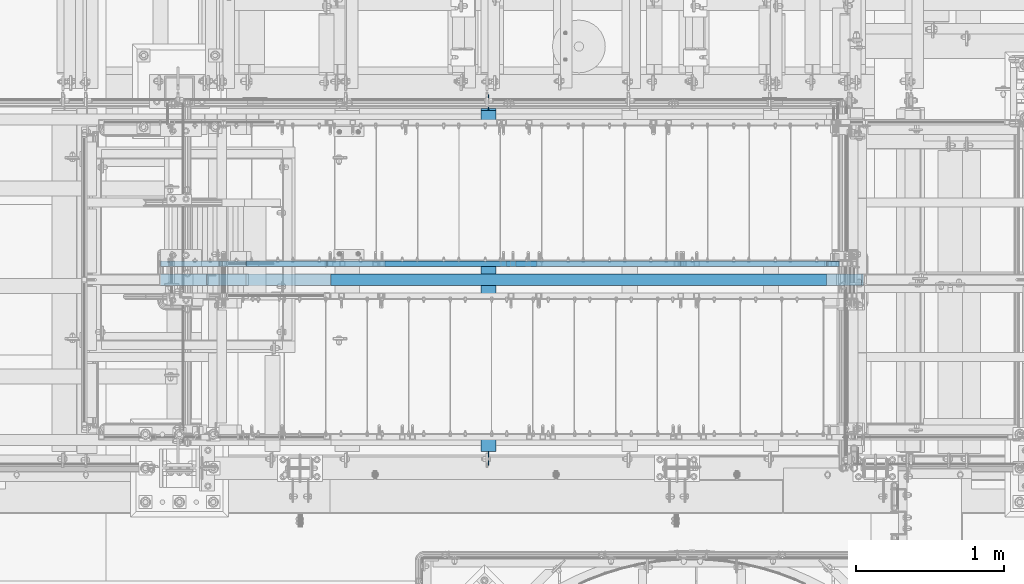
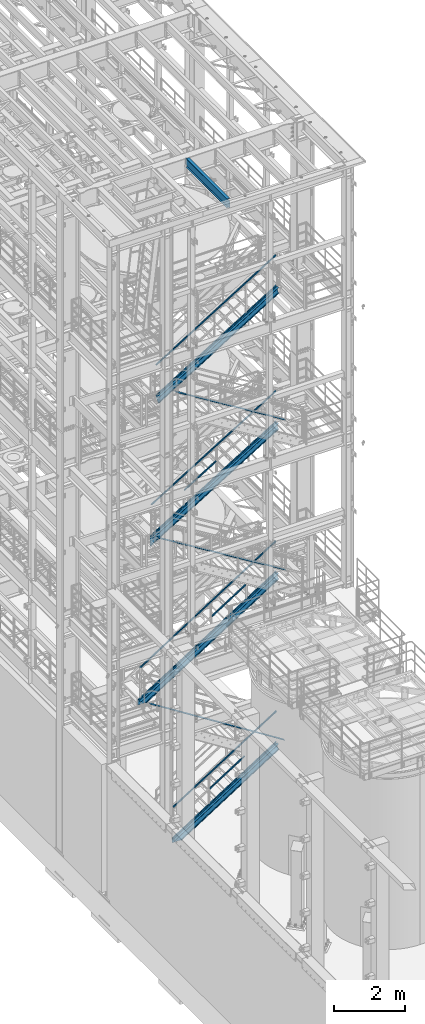
# One storey, part 975 of 1876: 18 members, 1 beam, 16 elements without a shape of their own.
"""IFC2X3 building model written with IfcOpenShell, lengths in millimetres."""

from ifc_helpers import new_model, si_unit, frame, origin_with_axes, place, context, subcontext, project, spatial, faceted_brep, material, type_object, element, aggregate, save


model = new_model("IFC2X3")

# Units and contexts
model_context = context("Model", 3, precision=1e-05, world=origin_with_axes())
body_context = subcontext(model_context, "Body", "Model", "MODEL_VIEW")
ifc_project = project(units=[si_unit("LENGTHUNIT", "METRE", prefix="MILLI"), si_unit("AREAUNIT", "SQUARE_METRE"), si_unit("VOLUMEUNIT", "CUBIC_METRE"), si_unit("MASSUNIT", "GRAM", prefix="KILO"), si_unit("TIMEUNIT", "SECOND"), si_unit("PLANEANGLEUNIT", "RADIAN"), si_unit("SOLIDANGLEUNIT", "STERADIAN"), si_unit("THERMODYNAMICTEMPERATUREUNIT", "DEGREE_CELSIUS"), si_unit("LUMINOUSINTENSITYUNIT", "LUMEN")], contexts=[model_context])

# Site, building, storey
site_placement = place(None, origin_with_axes())
site = spatial("IfcSite", under=ifc_project, at=site_placement, CompositionType="ELEMENT")
building_placement = place(site_placement, origin_with_axes())
building = spatial("IfcBuilding", under=site, at=building_placement, Name="Undefined", CompositionType="ELEMENT")
storey_placement = place(building_placement, origin_with_axes())
storey = spatial("IfcBuildingStorey", under=building, at=storey_placement, Name="Undefined", CompositionType="ELEMENT", Elevation=0.0)

# Assembly, beam
assembly_1_placement = place(storey_placement, origin_with_axes())
assembly_1 = element("IfcElementAssembly", 1, at=assembly_1_placement, inside=storey, Name="BEAM", AssemblyPlace="NOTDEFINED", PredefinedType="RIGID_FRAME")
ifc_material_1 = material(Name="STEEL/A992")
beam_type = type_object("IfcBeamType", Name="W12X16", PredefinedType="NOTDEFINED")
beam_placement = place(assembly_1_placement, frame((3810.0, -7112.0, 22402.8), z_axis=(0.0, 0.0, 1.0), x_axis=(0.0, 1.0, 0.0)))
beam = element("IfcBeam", 2, at=beam_placement, type_object=beam_type, material=ifc_material_1, Name="BEAM", ObjectType="W12X16", context=body_context, shape_type="Brep", body=[
    faceted_brep([(17.4625000000005, -3.17500000000018, -126.999999999999), (17.4625000000005, 3.17500000000018, -126.999999999999), (100.012500190734, 3.17500000000018, -126.999999999999), (100.012500190734, -3.17500000000018, -126.999999999999), (104.87257970878, 3.17500000000018, -127.966729922587), (104.87257970878, -3.17500000000018, -127.966729922587), (108.992756176934, 3.17500000000018, -130.719743823065), (108.992756176934, -3.17500000000018, -130.719743823065), (111.745770077412, 3.17500000000018, -134.839920291219), (111.745770077412, -3.17500000000018, -134.839920291219), (112.7125, -3.17500000000018, -139.699999809264), (112.7125, 3.17500000000018, -139.699999809264), (112.712500000001, 3.17500000000018, -146.049999999999), (112.7125, 50.8000000000002, -146.05), (112.7125, 50.8000000000002, -152.4), (112.7125, -50.8000000000002, -152.4), (112.7125, -50.8000000000002, -146.05), (112.712500000001, -3.17500000000018, -146.049999999999), (2412.20625, 50.8000000000002, 146.049999999999), (2412.20625, 3.17500000000018, 146.049999999999), (112.712500000001, 3.17500000000018, 146.05), (112.712500000001, 50.8000000000002, 146.049999999999), (100.012500190735, -3.17500000000018, 114.299999999996), (100.012500190735, 3.17500000000018, 114.299999999996), (17.4624999999996, 3.17500000000018, 114.299999999996), (17.4624999999996, -3.17500000000018, 114.299999999996), (104.872579708781, -3.17500000000018, 115.266729922583), (104.872579708781, 3.17500000000018, 115.266729922583), (108.992756176935, -3.17500000000018, 118.019743823061), (108.992756176935, 3.17500000000018, 118.019743823061), (111.745770077413, -3.17500000000018, 122.139920291214), (111.745770077413, 3.17500000000018, 122.139920291214), (112.712500000001, -3.17500000000018, 126.999999809261), (112.712500000001, 3.17500000000018, 126.999999809261), (2412.20625, -50.8000000000002, 152.400000000001), (2412.20625, 50.8000000000002, 152.400000000001), (112.712500000001, 50.8000000000002, 152.400000000001), (112.712500000001, -50.8000000000002, 152.400000000001), (2412.20625, -50.8000000000002, 146.049999999999), (112.712500000001, -50.8000000000002, 146.049999999999), (2412.20625, -3.17500000000018, 146.049999999999), (112.712500000001, -3.17500000000018, 146.05), (2412.20625, -3.17500000000018, 126.999999809268), (2412.20625, 3.17500000000018, 126.999999809268), (2413.17297992259, -3.17500000000018, 122.139920291222), (2413.17297992259, 3.17500000000018, 122.139920291222), (2415.92599382307, -3.17500000000018, 118.019743823068), (2415.92599382307, 3.17500000000018, 118.019743823068), (2420.04617029122, -3.17500000000018, 115.26672992259), (2420.04617029122, 3.17500000000018, 115.26672992259), (2424.90624980927, -3.17500000000018, 114.300000000003), (2424.90624980927, 3.17500000000018, 114.300000000003), (2520.15625, -3.17500000000018, 114.300000000003), (2520.15625, 3.17500000000018, 114.300000000003), (2520.15625, -3.17500000000018, -126.999999999996), (2520.15625, 3.17500000000018, -126.999999999996), (2437.60624980927, -3.17500000000018, -126.999999999996), (2437.60624980927, 3.17500000000018, -126.999999999996), (2432.74617029122, -3.17500000000018, -127.966729922584), (2432.74617029122, 3.17500000000018, -127.966729922584), (2428.62599382307, -3.17500000000018, -130.719743823061), (2428.62599382307, 3.17500000000018, -130.719743823061), (2425.87297992259, -3.17500000000018, -134.839920291215), (2425.87297992259, 3.17500000000018, -134.839920291215), (2424.90625, -3.17500000000018, -139.699999809261), (2424.90625, 3.17500000000018, -139.699999809261), (2424.90625, -3.17500000000018, -146.049999999999), (2424.90625, -50.8000000000002, -146.049999999999), (2424.90625, -50.8000000000002, -152.400000000001), (2424.90625, 50.8000000000002, -152.400000000001), (2424.90625, 50.8000000000002, -146.049999999999), (2424.90625, 3.17500000000018, -146.049999999999)], [[[0, 1, 2, 3]], [[3, 2, 4, 5]], [[5, 4, 6, 7]], [[7, 6, 8, 9]], [[10, 11, 12, 13, 14, 15, 16, 17]], [[9, 8, 11, 10]], [[18, 19, 20, 21]], [[22, 23, 24, 25]], [[26, 27, 23, 22]], [[28, 29, 27, 26]], [[30, 31, 29, 28]], [[32, 33, 31, 30]], [[34, 35, 36, 37]], [[38, 34, 37, 39]], [[40, 38, 39, 41]], [[37, 36, 21, 20, 33, 32, 41, 39]], [[35, 18, 21, 36]], [[34, 38, 40, 42, 43, 19, 18, 35]], [[44, 45, 43, 42]], [[46, 47, 45, 44]], [[48, 49, 47, 46]], [[50, 51, 49, 48]], [[52, 53, 51, 50]], [[53, 52, 54, 55]], [[54, 56, 57, 55]], [[58, 59, 57, 56]], [[60, 61, 59, 58]], [[62, 63, 61, 60]], [[64, 65, 63, 62]], [[66, 67, 68, 69, 70, 71, 65, 64]], [[67, 66, 17, 16]], [[68, 67, 16, 15]], [[69, 68, 15, 14]], [[70, 69, 14, 13]], [[71, 70, 13, 12]], [[6, 4, 2, 1, 24, 23, 27, 29, 31, 33, 20, 19, 43, 45, 47, 49, 51, 53, 55, 57, 59, 61, 63, 65, 71, 12, 11, 8]], [[25, 24, 1, 0]], [[66, 64, 62, 60, 58, 56, 54, 52, 50, 48, 46, 44, 42, 40, 41, 32, 30, 28, 26, 22, 25, 0, 3, 5, 7, 9, 10, 17]]]),
])
aggregate(assembly_1, [beam])

# Assembly, members
assembly_2_placement = place(storey_placement, origin_with_axes())
assembly_2 = element("IfcElementAssembly", 3, at=assembly_2_placement, inside=storey, Name="RAIL", AssemblyPlace="NOTDEFINED", PredefinedType="RIGID_FRAME")
ifc_material_2 = material()
member_type_1 = type_object("IfcMemberType", Name="HSS1-1/2X1-1/2X1/8", PredefinedType="NOTDEFINED")
member_1_placement = place(assembly_2_placement, frame((3911.60000001395, -5734.05000114554, 1451.89067373428), z_axis=(-0.53569741975471, 0.0, 0.844410015613355), x_axis=(0.844410015326383, 0.0, 0.535697420207059)))
member_1 = element("IfcMember", 4, at=member_1_placement, type_object=member_type_1, material=ifc_material_2, Name="RAIL", ObjectType="HSS1-1/2X1-1/2X1/8", context=body_context, shape_type="Brep", body=[
    faceted_brep([(10.4747262991696, -19.0499992349996, -19.0499992349991), (34.6455325374254, -19.0499992349996, 19.049999235012), (34.6455325374254, 19.0499992349996, 19.049999235012), (10.4747262991696, 19.0499992349996, -19.0499992349991), (32.6312986338025, 15.8749992829999, 15.8749992830109), (32.6312986338025, -15.8749992829999, 15.8749992830109), (12.4889602027924, -15.8749992829999, -15.8749992829981), (12.4889602027924, 15.8749992829999, -15.8749992829981), (1349.04246072927, 19.0499992349996, -19.049999234971), (1349.04246072927, -19.0499992349996, -19.049999234971), (1373.21326696754, -19.0499992349996, 19.0499992350346), (1373.21326696754, 19.0499992349996, 19.0499992350346), (1371.19903306392, -15.8749992829999, 15.8749992830342), (1371.19903306392, 15.8749992829999, 15.8749992830342), (1351.0566946329, 15.8749992829999, -15.8749992829707), (1351.0566946329, -15.8749992829999, -15.8749992829707)], [[[0, 1, 2, 3], [4, 5, 6, 7]], [[8, 9, 0, 3]], [[9, 10, 1, 0]], [[10, 11, 2, 1]], [[11, 8, 3, 2]], [[10, 9, 8, 11], [12, 13, 14, 15]], [[13, 12, 5, 4]], [[14, 13, 4, 7]], [[15, 14, 7, 6]], [[12, 15, 6, 5]]]),
])
member_2_placement = place(assembly_2_placement, frame((6096.0000003818, -5734.05000114554, 3371.08362061158), z_axis=(0.535697419754711, 0.0, -0.844410015613354), x_axis=(-0.844410015613354, 0.0, -0.53569741975471)))
member_2 = element("IfcMember", 5, at=member_2_placement, type_object=member_type_1, material=ifc_material_2, Name="RAIL", ObjectType="HSS1-1/2X1-1/2X1/8", context=body_context, shape_type="Brep", body=[
    faceted_brep([(-4.61079482035893, 15.8749992829999, -15.8749992830034), (-4.61079482035893, -15.8749992829999, -15.8749992830034), (3979.31187617968, -15.8749992829999, -15.8749992819418), (3979.31187617968, 15.8749992829999, -15.8749992819418), (4.61079481841625, -15.8749992829999, 15.8749992830026), (3961.85399909883, -15.8749992829999, 15.8749992840581), (4.61079481841625, 15.8749992829999, 15.8749992830026), (3961.85399909883, 15.8749992829999, 15.8749992840581), (-5.53295381194494, 19.0499992349996, -19.0499992350046), (5.53295381000225, 19.0499992349996, 19.0499992350038), (3960.10821133829, 19.0499992349996, 19.0499992360577), (3981.05766394022, 19.0499992349996, -19.0499992339418), (5.53295381000225, -19.0499992349996, 19.0499992350038), (3960.10821133829, -19.0499992349996, 19.0499992360577), (-5.53295381194494, -19.0499992349996, -19.0499992350046), (3981.05766394022, -19.0499992349996, -19.0499992339418)], [[[0, 1, 2, 3]], [[1, 4, 5, 2]], [[4, 6, 7, 5]], [[6, 0, 3, 7]], [[8, 9, 10, 11]], [[9, 12, 13, 10]], [[12, 14, 15, 13]], [[14, 8, 11, 15]], [[13, 15, 11, 10], [5, 7, 3, 2]], [[14, 12, 9, 8], [6, 4, 1, 0]]]),
])
aggregate(assembly_2, [member_1, member_2])

assembly_3_placement = place(storey_placement, origin_with_axes())
assembly_3 = element("IfcElementAssembly", 6, at=assembly_3_placement, inside=storey, Name="RAIL", AssemblyPlace="NOTDEFINED", PredefinedType="RIGID_FRAME")
member_3_placement = place(assembly_3_placement, frame((3975.0999976701, -5734.05000114554, 7346.66136059212), z_axis=(-0.536875491934336, 0.0, 0.843661487896813), x_axis=(0.843661487896813, 0.0, 0.536875491934336)))
member_3 = element("IfcMember", 7, at=member_3_placement, type_object=member_type_1, material=ifc_material_2, Name="RAIL", ObjectType="HSS1-1/2X1-1/2X1/8", context=body_context, shape_type="Brep", body=[
    faceted_brep([(10.4574188235219, -19.0499992349996, -19.0499992349946), (34.7028723789208, -19.0499992349996, 19.0499992350083), (34.7028723789208, 19.0499992349996, 19.0499992350083), (10.4574188235219, 19.0499992349996, -19.0499992349946), (32.6824178653787, 15.8749992829999, 15.8749992830085), (32.6824178653787, -15.8749992829999, 15.8749992830085), (12.4778733370622, -15.8749992829999, -15.8749992829939), (12.4778733370622, 15.8749992829999, -15.8749992829939), (1327.63263086906, 19.0499992349996, -19.0499992348527), (1327.63263086906, -19.0499992349996, -19.0499992348527), (1351.87808442446, -19.0499992349996, 19.0499992351442), (1351.87808442446, 19.0499992349996, 19.0499992351442), (1349.85762991092, -15.8749992829999, 15.8749992831449), (1349.85762991092, 15.8749992829999, 15.8749992831449), (1329.6530853826, 15.8749992829999, -15.8749992828534), (1329.6530853826, -15.8749992829999, -15.8749992828534)], [[[0, 1, 2, 3], [4, 5, 6, 7]], [[8, 9, 0, 3]], [[9, 10, 1, 0]], [[10, 11, 2, 1]], [[11, 8, 3, 2]], [[10, 9, 8, 11], [12, 13, 14, 15]], [[13, 12, 5, 4]], [[14, 13, 4, 7]], [[15, 14, 7, 6]], [[12, 15, 6, 5]]]),
])
member_4_placement = place(assembly_3_placement, frame((6081.03214535919, -5734.05000114554, 9220.19999999963), z_axis=(0.536875491934335, 0.0, -0.843661487896814), x_axis=(-0.843661487896813, 0.0, -0.536875491934336)))
member_4 = element("IfcMember", 8, at=member_4_placement, type_object=member_type_1, material=ifc_material_2, Name="RAIL", ObjectType="HSS1-1/2X1-1/2X1/8", context=body_context, shape_type="Brep", body=[
    faceted_brep([(-4.62281069927667, 15.8749992829999, -15.8749992829999), (-4.62281069927667, -15.8749992829999, -15.8749992829999), (5229.56696317395, -15.8749992829999, -15.8749992811681), (5229.56696317395, 15.8749992829999, -15.8749992811681), (4.62281070567769, -15.8749992829999, 15.8749992829999), (5212.13793187573, -15.8749992829999, 15.8749992848452), (4.62281070567769, 15.8749992829999, 15.8749992829999), (5212.13793187573, 15.8749992829999, 15.8749992848452), (-5.54737286755244, 19.0499992349996, -19.0499992349996), (5.54737287395346, 19.0499992349996, 19.0499992349996), (5210.39502869354, 19.0499992349996, 19.0499992368468), (5231.30986635614, 19.0499992349996, -19.0499992331688), (5.54737287395346, -19.0499992349996, 19.0499992349996), (5210.39502869354, -19.0499992349996, 19.0499992368468), (-5.54737286755244, -19.0499992349996, -19.0499992349996), (5231.30986635614, -19.0499992349996, -19.0499992331688)], [[[0, 1, 2, 3]], [[1, 4, 5, 2]], [[4, 6, 7, 5]], [[6, 0, 3, 7]], [[8, 9, 10, 11]], [[9, 12, 13, 10]], [[12, 14, 15, 13]], [[14, 8, 11, 15]], [[13, 15, 11, 10], [5, 7, 3, 2]], [[14, 12, 9, 8], [6, 4, 1, 0]]]),
])
aggregate(assembly_3, [member_3, member_4])

assembly_4_placement = place(storey_placement, origin_with_axes())
assembly_4 = element("IfcElementAssembly", 9, at=assembly_4_placement, inside=storey, Name="RAIL", AssemblyPlace="NOTDEFINED", PredefinedType="RIGID_FRAME")
member_5_placement = place(assembly_4_placement, frame((3092.45000026332, -5734.05000114554, 12004.8866662211), z_axis=(-0.523953411146183, 0.0, 0.851746924237639), x_axis=(0.851746924237639, 0.0, 0.523953411146184)))
member_5 = element("IfcMember", 10, at=member_5_placement, type_object=member_type_1, material=ifc_material_2, Name="RAIL", ObjectType="HSS1-1/2X1-1/2X1/8", context=body_context, shape_type="Brep", body=[
    faceted_brep([(1234.38228196586, -19.0499992349996, 19.0499992361129), (1210.94501017189, -19.0499992349996, -19.0499992339264), (1210.94501017189, 19.0499992349996, -19.0499992339264), (1234.38228196586, 19.0499992349996, 19.0499992361129), (1232.42917593412, -15.8749992829999, 15.8749992841094), (1232.42917593412, 15.8749992829999, 15.8749992841094), (1212.89811620362, 15.8749992829999, -15.874999281923), (1212.89811620362, -15.8749992829999, -15.874999281923), (10.6471616099025, 19.0499992349996, -19.0499992350033), (34.0844334038557, 19.0499992349996, 19.0499992349978), (34.0844334038557, -19.0499992349996, 19.0499992349978), (10.6471616099025, -19.0499992349996, -19.0499992350033), (32.1313273721225, 15.8749992829999, 15.874999282998), (32.1313273721225, -15.8749992829999, 15.874999282998), (12.6002676416374, -15.8749992829999, -15.8749992830035), (12.6002676416374, 15.8749992829999, -15.8749992830035)], [[[0, 1, 2, 3], [4, 5, 6, 7]], [[8, 9, 3, 2]], [[9, 10, 0, 3]], [[10, 11, 1, 0]], [[11, 8, 2, 1]], [[11, 10, 9, 8], [12, 13, 14, 15]], [[14, 13, 4, 7]], [[15, 14, 7, 6]], [[12, 15, 6, 5]], [[13, 12, 5, 4]]]),
])
member_6_placement = place(assembly_4_placement, frame((6080.51600983971, -5734.05000114554, 14376.3999999962), z_axis=(0.523953411146183, 0.0, -0.851746924237639), x_axis=(-0.851746924237639, 0.0, -0.523953411146184)))
member_6 = element("IfcMember", 11, at=member_6_placement, type_object=member_type_1, material=ifc_material_2, Name="RAIL", ObjectType="HSS1-1/2X1-1/2X1/8", context=body_context, shape_type="Brep", body=[
    faceted_brep([(-4.49184492785935, 15.8749992829999, -15.8749992829999), (-4.49184492785935, -15.8749992829999, -15.8749992829999), (4762.06386347793, -15.8749992829999, -15.8749992840985), (4762.06386347793, 15.8749992829999, -15.8749992840985), (4.49184492431232, -15.8749992829999, 15.8749992829999), (4744.31859422905, -15.8749992829999, 15.8749992819121), (4.49184492431232, 15.8749992829999, 15.8749992829999), (4744.31859422905, 15.8749992829999, 15.8749992819121), (-5.39021394007068, 19.0499992349996, -19.0499992349996), (5.39021393652274, 19.0499992349996, 19.0499992349996), (4742.54406725084, 19.0499992349996, 19.0499992339137), (4763.83839045614, 19.0499992349996, -19.0499992360983), (5.39021393652274, -19.0499992349996, 19.0499992349996), (4742.54406725084, -19.0499992349996, 19.0499992339137), (-5.39021394007068, -19.0499992349996, -19.0499992349996), (4763.83839045614, -19.0499992349996, -19.0499992360983)], [[[0, 1, 2, 3]], [[1, 4, 5, 2]], [[4, 6, 7, 5]], [[6, 0, 3, 7]], [[8, 9, 10, 11]], [[9, 12, 13, 10]], [[12, 14, 15, 13]], [[14, 8, 11, 15]], [[13, 15, 11, 10], [5, 7, 3, 2]], [[14, 12, 9, 8], [6, 4, 1, 0]]]),
])
aggregate(assembly_4, [member_5, member_6])

# Assembly, member
assembly_5_placement = place(storey_placement, origin_with_axes())
assembly_5 = element("IfcElementAssembly", 12, at=assembly_5_placement, inside=storey, Name="RAIL", AssemblyPlace="NOTDEFINED", PredefinedType="RIGID_FRAME")
member_7_placement = place(assembly_5_placement, frame((6080.62411538881, -5734.05000114554, 19050.0000003721), z_axis=(0.526627379729771, 0.0, -0.850096231563789), x_axis=(-0.850096231563789, 0.0, -0.526627379729771)))
member_7 = element("IfcMember", 13, at=member_7_placement, type_object=member_type_1, material=ifc_material_2, Name="RAIL", ObjectType="HSS1-1/2X1-1/2X1/8", context=body_context, shape_type="Brep", body=[
    faceted_brep([(-4.5187969689996, 15.8749992829999, -15.8749992829871), (-4.5187969689996, -15.8749992829999, -15.8749992829871), (4579.03162456834, -15.8749992829999, -15.8749992763478), (4579.03162456834, 15.8749992829999, -15.8749992763478), (4.51879699284473, -15.8749992829999, 15.8749992829871), (4588.06921853025, -15.8749992829999, 15.8749992896428), (4.51879699284473, 15.8749992829999, 15.8749992829871), (4588.06921853025, 15.8749992829999, 15.8749992896428), (-5.42255639234099, 19.0499992349996, -19.0499992349833), (5.42255641618613, 19.0499992349996, 19.0499992349851), (4588.97297795359, 19.0499992349996, 19.0499992416389), (4578.12786514499, 19.0499992349996, -19.0499992283476), (5.42255641618613, -19.0499992349996, 19.0499992349851), (4588.97297795359, -19.0499992349996, 19.0499992416389), (-5.42255639234099, -19.0499992349996, -19.0499992349833), (4578.12786514499, -19.0499992349996, -19.0499992283476)], [[[0, 1, 2, 3]], [[1, 4, 5, 2]], [[4, 6, 7, 5]], [[6, 0, 3, 7]], [[8, 9, 10, 11]], [[9, 12, 13, 10]], [[12, 14, 15, 13]], [[14, 8, 11, 15]], [[13, 15, 11, 10], [5, 7, 3, 2]], [[14, 12, 9, 8], [6, 4, 1, 0]]]),
])
aggregate(assembly_5, [member_7])

assembly_6_placement = place(storey_placement, origin_with_axes())
assembly_6 = element("IfcElementAssembly", 14, at=assembly_6_placement, inside=storey, Name="STRINGER", AssemblyPlace="NOTDEFINED", PredefinedType="RIGID_FRAME")
ifc_material_3 = material(Name="STEEL/A36")
member_type_2 = type_object("IfcMemberType", Name="MC12X10.6", PredefinedType="NOTDEFINED")
member_8_placement = place(assembly_6_placement, frame((2257.43103902822, -5734.05000114558, 15465.2243393473), z_axis=(-0.526650190166568, 0.0, 0.850082100268861), x_axis=(0.850082100268861, 0.0, 0.526650190166567)))
member_8 = element("IfcMember", 15, at=member_8_placement, type_object=member_type_2, material=ifc_material_3, Name="STRINGER", ObjectType="MC12X10.6", context=body_context, shape_type="Brep", body=[
    faceted_brep([(-86.7653266056568, 19.0500000000002, -152.399999999963), (-1.68647966347635e-06, 19.0500000000002, 152.400000000001), (4601.43790882204, 19.0500000000002, 152.399999997626), (4514.67258218764, 19.0500000000002, -152.400000002352), (-1.68647966347635e-06, -19.0500000000002, 152.400000000001), (4601.43790882204, -19.0500000000002, 152.399999997626), (-2.15159931068411, -19.0500000000002, 144.841595000014), (4599.28630948261, -19.0500000000002, 144.841594997624), (-2.34044946693575, 14.2875000000004, 144.178178750015), (4599.09745932636, 14.2875000000004, 144.178178747625), (-84.4248771099683, 14.2875000000004, -144.178178749964), (4517.01303168332, 14.2875000000004, -144.178178752352), (-84.6137272662218, -19.0500000000002, -144.841594999965), (4516.82418152707, -19.0500000000002, -144.841595002352), (-86.7653266056568, -19.0500000000002, -152.399999999963), (4514.67258218764, -19.0500000000002, -152.400000002352)], [[[0, 1, 2, 3]], [[1, 4, 5, 2]], [[4, 6, 7, 5]], [[6, 8, 9, 7]], [[8, 10, 11, 9]], [[10, 12, 13, 11]], [[12, 14, 15, 13]], [[14, 0, 3, 15]], [[5, 7, 9, 11, 13, 15, 3, 2]], [[14, 12, 10, 8, 6, 4, 1, 0]]]),
])
aggregate(assembly_6, [member_8])

assembly_7_placement = place(storey_placement, origin_with_axes())
assembly_7 = element("IfcElementAssembly", 16, at=assembly_7_placement, inside=storey, Name="STRINGER", AssemblyPlace="NOTDEFINED", PredefinedType="RIGID_FRAME")
member_9_placement = place(assembly_7_placement, frame((1977.66354904, -5734.05000114552, 10636.6187687464), z_axis=(-0.523953411146183, 0.0, 0.851746924237639), x_axis=(0.851746924237639, 0.0, 0.523953411146184)))
member_9 = element("IfcMember", 17, at=member_9_placement, type_object=member_type_2, material=ifc_material_3, Name="STRINGER", ObjectType="MC12X10.6", context=body_context, shape_type="Brep", body=[
    faceted_brep([(-74.6865609331826, 19.0500000000002, -152.400000000033), (112.811620947801, 19.0500000000002, 152.400000000029), (4920.47564757863, 19.0500000000002, 152.399999999499), (4834.23222109767, 19.0500000000002, -152.400000000574), (112.811620947801, -19.0500000000002, 152.400000000029), (4920.47564757863, -19.0500000000002, 152.399999999499), (108.162056658365, -19.0500000000002, 144.841595000027), (4918.33699027571, -19.0500000000002, 144.841594999496), (107.753955146864, 14.2875000000004, 144.178178750026), (4918.14927606776, 14.2875000000004, 144.178178749497), (-69.6288951322458, 14.2875000000004, -144.178178750032), (4836.55859260854, 14.2875000000004, -144.178178750573), (-70.0369966437447, -19.0500000000002, -144.84159500003), (4836.37087840059, -19.0500000000002, -144.841595000573), (-74.6865609331826, -19.0500000000002, -152.400000000033), (4834.23222109767, -19.0500000000002, -152.400000000574)], [[[0, 1, 2, 3]], [[1, 4, 5, 2]], [[4, 6, 7, 5]], [[6, 8, 9, 7]], [[8, 10, 11, 9]], [[10, 12, 13, 11]], [[12, 14, 15, 13]], [[14, 0, 3, 15]], [[5, 7, 9, 11, 13, 15, 3, 2]], [[14, 12, 10, 8, 6, 4, 1, 0]]]),
])
aggregate(assembly_7, [member_9])

assembly_8_placement = place(storey_placement, origin_with_axes())
assembly_8 = element("IfcElementAssembly", 18, at=assembly_8_placement, inside=storey, Name="STRINGER", AssemblyPlace="NOTDEFINED", PredefinedType="RIGID_FRAME")
member_10_placement = place(assembly_8_placement, frame((1420.62332830689, -5734.05000113593, 5037.15098930462), z_axis=(-0.536875491934336, 0.0, 0.843661487896813), x_axis=(0.843661487896813, 0.0, 0.536875491934336)))
member_10 = element("IfcMember", 19, at=member_10_placement, type_object=member_type_2, material=ifc_material_3, Name="STRINGER", ObjectType="MC12X10.6", context=body_context, shape_type="Brep", body=[
    faceted_brep([(412.826792026975, 14.2875000000004, -144.178178750052), (413.869303275739, -19.0500000000002, -144.841595000053), (5543.42623306462, -19.0500000000002, -144.841595001245), (5543.61942033262, 14.2875000000004, -144.178178751245), (425.746796833087, -19.0500000000002, -152.400000000053), (5541.2252203333, -19.0500000000002, -152.400000001242), (425.746796833087, 19.0500000000002, -152.400000000053), (5541.2252203333, 19.0500000000002, -152.400000001242), (5629.9831898395, -19.0500000000002, 152.399999998643), (5627.78217710819, -19.0500000000002, 144.841594998646), (5627.58898984018, 14.2875000000004, 144.178178748647), (5629.9831898395, 19.0500000000002, 152.399999998643), (309.835757404233, -19.0500000000002, 152.39999999988), (305.025863307626, -19.0500000000002, 144.841594999885), (304.603689329853, 14.2875000000004, 144.178178749884), (205.188939344374, 14.2875000000004, -12.0449996135767), (205.188939344374, 19.0500000000002, -12.0449996135767), (309.835757404233, 19.0500000000002, 152.39999999988)], [[[0, 1, 2, 3]], [[1, 4, 5, 2]], [[4, 6, 7, 5]], [[8, 9, 10, 3, 2, 5, 7, 11]], [[9, 8, 12, 13]], [[10, 9, 13, 14]], [[0, 3, 10, 14, 15]], [[6, 4, 1, 0, 15, 16]], [[11, 7, 6, 16, 17]], [[8, 11, 17, 12]], [[16, 15, 14, 13, 12, 17]]]),
])
aggregate(assembly_8, [member_10])

assembly_9_placement = place(storey_placement, origin_with_axes())
assembly_9 = element("IfcElementAssembly", 20, at=assembly_9_placement, inside=storey, Name="STRINGER", AssemblyPlace="NOTDEFINED", PredefinedType="RIGID_FRAME")
member_11_placement = place(assembly_9_placement, frame((2538.06301503565, -5734.05000121171, -103.288086390241), z_axis=(-0.53569741975471, 0.0, 0.844410015613355), x_axis=(0.844410015326383, 0.0, 0.535697420207059)))
member_11 = element("IfcMember", 21, at=member_11_placement, type_object=member_type_2, material=ifc_material_3, Name="STRINGER", ObjectType="MC12X10.6", context=body_context, shape_type="Brep", body=[
    faceted_brep([(443.630142178898, 14.2875000000004, -144.178178750028), (444.675873043678, -19.0500000000002, -144.841595000028), (4215.13287502114, -19.0500000000002, -144.841595000213), (4215.32556014534, 14.2875000000004, -144.178178750212), (456.590048189388, -19.0500000000002, -152.400000000029), (4212.93758329258, -19.0500000000002, -152.400000000214), (456.590048189388, 19.0500000000002, -152.400000000029), (4212.93758329258, 19.0500000000002, -152.400000000214), (4301.46484782315, -19.0500000000002, 152.399999999795), (4299.26955609459, -19.0500000000002, 144.841594999795), (4299.07687097039, 14.2875000000004, 144.178178749796), (4301.46484782315, 19.0500000000002, 152.399999999795), (309.5383371051, -19.0500000000002, 152.399999999991), (304.743251801641, -19.0500000000002, 144.841594999991), (304.322377621116, 14.2875000000004, 144.178178749991), (213.862268724054, 14.2875000000004, 1.58756854855847), (213.862268724054, 19.0500000000002, 1.58756854855847), (309.5383371051, 19.0500000000002, 152.399999999991)], [[[0, 1, 2, 3]], [[1, 4, 5, 2]], [[4, 6, 7, 5]], [[8, 9, 10, 3, 2, 5, 7, 11]], [[9, 8, 12, 13]], [[10, 9, 13, 14]], [[0, 3, 10, 14, 15]], [[6, 4, 1, 0, 15, 16]], [[11, 7, 6, 16, 17]], [[8, 11, 17, 12]], [[16, 15, 14, 13, 12, 17]]]),
])
aggregate(assembly_9, [member_11])

assembly_10_placement = place(storey_placement, origin_with_axes())
assembly_10 = element("IfcElementAssembly", 22, at=assembly_10_placement, inside=storey, Name="ref.", AssemblyPlace="NOTDEFINED", PredefinedType="RIGID_FRAME")
ifc_material_4 = material(Name="STEEL/Steel_Undefined")
member_type_3 = type_object("IfcMemberType", PredefinedType="NOTDEFINED")
member_12_placement = place(assembly_10_placement, frame((2178.60713901935, -5842.00000114554, 15592.0777950691), z_axis=(0.0, -1.0, 0.0), x_axis=(0.850096231563789, 0.0, 0.526627379729772)))
member_12 = element("IfcMember", 23, at=member_12_placement, type_object=member_type_3, material=ifc_material_4, Name="ref.", context=body_context, shape_type="Brep", body=[
    faceted_brep([(0.0, 3.17500000000018, -38.1000000000004), (0.0, 3.17500000000018, 38.1000000000004), (4601.63721661283, 3.17499999955544, 38.1000000000004), (4601.63721661283, 3.17499999955544, -38.1000000000004), (0.0, -3.17500000000018, 38.1000000000004), (4601.63721661283, -3.17500000043583, 38.1000000000004), (0.0, -3.17500000000018, -38.1000000000004), (4601.63721661283, -3.17500000043583, -38.1000000000004)], [[[0, 1, 2, 3]], [[1, 4, 5, 2]], [[4, 6, 7, 5]], [[6, 0, 3, 7]], [[5, 7, 3, 2]], [[6, 4, 1, 0]]]),
])
aggregate(assembly_10, [member_12])

assembly_11_placement = place(storey_placement, origin_with_axes())
assembly_11 = element("IfcElementAssembly", 24, at=assembly_11_placement, inside=storey, Name="ref.", AssemblyPlace="NOTDEFINED", PredefinedType="RIGID_FRAME")
member_13_placement = place(assembly_11_placement, frame((6322.92788507087, -5842.00000114554, 13377.7764519202), z_axis=(0.0, 1.0, 0.0), x_axis=(-0.850081987723821, 0.0, 0.5266503718289)))
member_13 = element("IfcMember", 25, at=member_13_placement, type_object=member_type_3, material=ifc_material_4, Name="ref.", context=body_context, shape_type="Brep", body=[
    faceted_brep([(0.0, 3.17500000000018, -38.1000000000004), (0.0, 3.17500000000018, 38.1000000000004), (4204.49980971859, 3.17499999916618, 38.1000000000004), (4204.49980971859, 3.17499999916618, -38.1000000000004), (0.0, -3.17500000000018, 38.1000000000004), (4204.49980971859, -3.17500000083601, 38.1000000000004), (0.0, -3.17500000000018, -38.1000000000004), (4204.49980971859, -3.17500000083601, -38.1000000000004)], [[[0, 1, 2, 3]], [[1, 4, 5, 2]], [[4, 6, 7, 5]], [[6, 0, 3, 7]], [[5, 7, 3, 2]], [[6, 4, 1, 0]]]),
])
aggregate(assembly_11, [member_13])

assembly_12_placement = place(storey_placement, origin_with_axes())
assembly_12 = element("IfcElementAssembly", 26, at=assembly_12_placement, inside=storey, Name="ref.", AssemblyPlace="NOTDEFINED", PredefinedType="RIGID_FRAME")
member_14_placement = place(assembly_12_placement, frame((1995.56355242225, -5842.00000114094, 10822.8287371283), z_axis=(0.0, -1.0, 0.0), x_axis=(0.851746924237639, 0.0, 0.523953411146184)))
member_14 = element("IfcMember", 27, at=member_14_placement, type_object=member_type_3, material=ifc_material_4, Name="ref.", context=body_context, shape_type="Brep", body=[
    faceted_brep([(0.0, 3.17500000000018, -38.1000000000004), (0.0, 3.17500000000018, 38.1000000000004), (4807.66402661751, 3.17499999947086, 38.1000000000004), (4807.66402661751, 3.17499999947086, -38.1000000000004), (0.0, -3.17500000000018, 38.1000000000004), (4807.66402661751, -3.17500000053224, 38.1000000000004), (0.0, -3.17500000000018, -38.1000000000004), (4807.66402661751, -3.17500000053224, -38.1000000000004)], [[[0, 1, 2, 3]], [[1, 4, 5, 2]], [[4, 6, 7, 5]], [[6, 0, 3, 7]], [[5, 7, 3, 2]], [[6, 4, 1, 0]]]),
])
aggregate(assembly_12, [member_14])

assembly_13_placement = place(storey_placement, origin_with_axes())
assembly_13 = element("IfcElementAssembly", 28, at=assembly_13_placement, inside=storey, Name="ref.", AssemblyPlace="NOTDEFINED", PredefinedType="RIGID_FRAME")
member_15_placement = place(assembly_13_placement, frame((6335.63644134055, -5842.00000114094, 8213.4790449926), z_axis=(0.0, 1.0, 0.0), x_axis=(-0.851745649804232, 0.0, 0.523955482879573)))
member_15 = element("IfcMember", 29, at=member_15_placement, type_object=member_type_3, material=ifc_material_4, Name="ref.", context=body_context, shape_type="Brep", body=[
    faceted_brep([(0.0, 3.17500000000018, -38.1000000000004), (0.0, 3.17500000000018, 38.1000000000004), (4867.28690671974, 3.17500000434848, 38.1000000000004), (4867.28690671974, 3.17500000434848, -38.1000000000004), (0.0, -3.17500000000018, 38.1000000000004), (4867.28690671974, -3.17499999565371, 38.1000000000004), (0.0, -3.17500000000018, -38.1000000000004), (4867.28690671974, -3.17499999565371, -38.1000000000004)], [[[0, 1, 2, 3]], [[1, 4, 5, 2]], [[4, 6, 7, 5]], [[6, 0, 3, 7]], [[5, 7, 3, 2]], [[6, 4, 1, 0]]]),
])
aggregate(assembly_13, [member_15])

assembly_14_placement = place(storey_placement, origin_with_axes())
assembly_14 = element("IfcElementAssembly", 30, at=assembly_14_placement, inside=storey, Name="ref.", AssemblyPlace="NOTDEFINED", PredefinedType="RIGID_FRAME")
member_16_placement = place(assembly_14_placement, frame((1601.90457887086, -5842.00000113861, 5329.38959966366), z_axis=(0.0, -1.0, 0.0), x_axis=(0.843661487896813, 0.0, 0.536875491934336)))
member_16 = element("IfcMember", 31, at=member_16_placement, type_object=member_type_3, material=ifc_material_4, Name="ref.", context=body_context, shape_type="Brep", body=[
    faceted_brep([(0.0, 3.17500000000018, -38.1000000000004), (0.0, 3.17500000000018, 38.1000000000004), (5320.14743340394, 3.175000001223, 38.1000000000004), (5320.14743340394, 3.175000001223, -38.1000000000004), (0.0, -3.17500000000018, 38.1000000000004), (5320.14743340394, -3.17499999877509, 38.1000000000004), (0.0, -3.17500000000018, -38.1000000000004), (5320.14743340394, -3.17499999877509, -38.1000000000004)], [[[0, 1, 2, 3]], [[1, 4, 5, 2]], [[4, 6, 7, 5]], [[6, 0, 3, 7]], [[5, 7, 3, 2]], [[6, 4, 1, 0]]]),
])
aggregate(assembly_14, [member_16])

assembly_15_placement = place(storey_placement, origin_with_axes())
assembly_15 = element("IfcElementAssembly", 32, at=assembly_15_placement, inside=storey, Name="ref.", AssemblyPlace="NOTDEFINED", PredefinedType="RIGID_FRAME")
member_17_placement = place(assembly_15_placement, frame((6284.79916107386, -5842.00000113818, 2388.08134329387), z_axis=(0.0, 1.0, 0.0), x_axis=(-0.844410015326383, 0.0, 0.535697420207059)))
member_17 = element("IfcMember", 33, at=member_17_placement, type_object=member_type_3, material=ifc_material_4, Name="ref.", context=body_context, shape_type="Brep", body=[
    faceted_brep([(0.0, 3.17500000000018, -38.1000000000004), (0.0, 3.17500000000018, 38.1000000000004), (5180.09337031023, 3.17500000059408, 38.1000000000004), (5180.09337031023, 3.17500000059408, -38.1000000000004), (0.0, -3.17500000000018, 38.1000000000004), (5180.09337031022, -3.17499999940628, 38.1000000000004), (0.0, -3.17500000000018, -38.1000000000004), (5180.09337031022, -3.17499999940628, -38.1000000000004)], [[[0, 1, 2, 3]], [[1, 4, 5, 2]], [[4, 6, 7, 5]], [[6, 0, 3, 7]], [[5, 7, 3, 2]], [[6, 4, 1, 0]]]),
])
aggregate(assembly_15, [member_17])

assembly_16_placement = place(storey_placement, origin_with_axes())
assembly_16 = element("IfcElementAssembly", 34, at=assembly_16_placement, inside=storey, Name="ref.", AssemblyPlace="NOTDEFINED", PredefinedType="RIGID_FRAME")
member_18_placement = place(assembly_16_placement, frame((2719.50083964019, -5842.00000113818, 188.537886691764), z_axis=(0.0, -1.0, 0.0), x_axis=(0.844410015326383, 0.0, 0.535697420207059)))
member_18 = element("IfcMember", 35, at=member_18_placement, type_object=member_type_3, material=ifc_material_4, Name="ref.", context=body_context, shape_type="Brep", body=[
    faceted_brep([(0.0, 3.17500000000018, -38.1000000000004), (0.0, 3.17500000000018, 38.1000000000004), (3991.92651161048, 3.17499999980555, 38.1000000000004), (3991.92651161048, 3.17499999980555, -38.1000000000004), (0.0, -3.17500000000018, 38.1000000000004), (3991.92651161048, -3.17500000019527, 38.1000000000004), (0.0, -3.17500000000018, -38.1000000000004), (3991.92651161048, -3.17500000019527, -38.1000000000004)], [[[0, 1, 2, 3]], [[1, 4, 5, 2]], [[4, 6, 7, 5]], [[6, 0, 3, 7]], [[5, 7, 3, 2]], [[6, 4, 1, 0]]]),
])
aggregate(assembly_16, [member_18])

save(model, "model.ifc")
